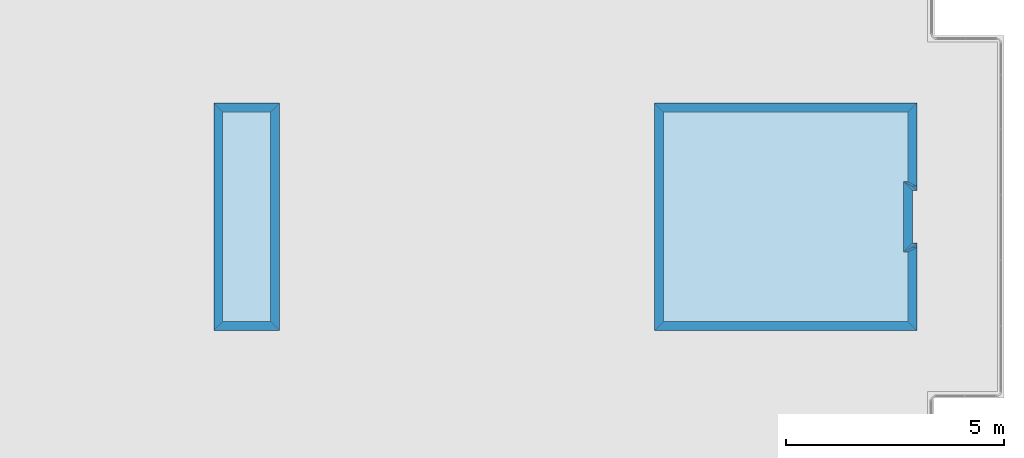
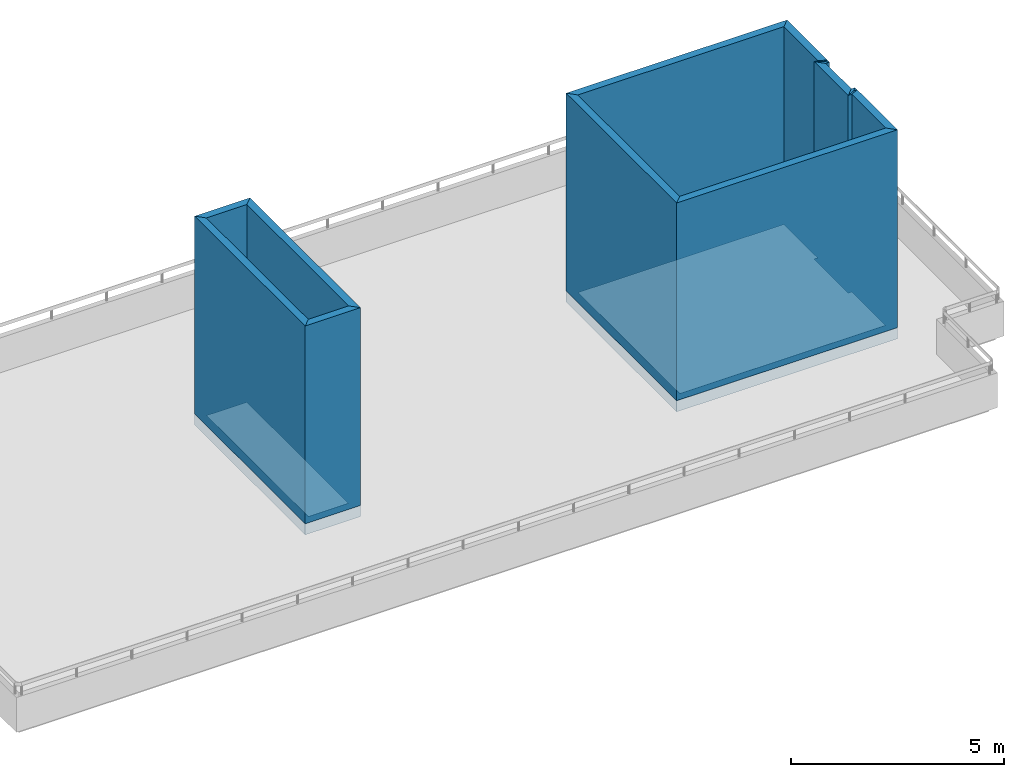
# One storey, part 1 of 34: 14 walls, 4 slabs.
"""IFC2X3 building model written with IfcOpenShell, lengths in metres."""

import ifcopenshell
import ifcopenshell.guid

model = None  # the IFC model being written
_history = None  # IfcOwnerHistory: only IFC2X3 demands one
_inside = {}  # id of a spatial element -> (the spatial element, [elements in it])
_under = {}  # id of a project, library or spatial element -> (it, [spatial elements below it])
_declared = {}  # id of a project -> (the project, [libraries it declares])
_typed = {}  # id of a type object -> (the type object, [elements of that type])
_made_of = {}  # id of a material, layer set ... -> (it, [elements and type objects made of it])


def new_model(schema):
    """Start an empty IFC model of exactly this schema.

    Asked for "IFC4X3", IfcOpenShell would pick the latest addendum, in which some entities
    have other attributes; the version numbers below select the first issue.
    IFC2X3 requires an IfcOwnerHistory on every rooted entity: one is made here for all.
    """
    global model, _history
    if schema == "IFC4X3":
        model = ifcopenshell.file(schema_version=(4, 3, 0, 0))
    else:
        model = ifcopenshell.file(schema=schema)
    _inside.clear()
    _under.clear()
    _declared.clear()
    _typed.clear()
    _made_of.clear()
    _history = None
    if model.schema == "IFC2X3":
        org = make("IfcOrganization", Name="unknown")
        user = make(
            "IfcPersonAndOrganization",
            ThePerson=make("IfcPerson", FamilyName="unknown"),
            TheOrganization=org,
        )
        app = make(
            "IfcApplication",
            ApplicationDeveloper=org,
            Version="unknown",
            ApplicationFullName="unknown",
            ApplicationIdentifier="unknown",
        )
        _history = make(
            "IfcOwnerHistory",
            OwningUser=user,
            OwningApplication=app,
            ChangeAction="ADDED",
            CreationDate=0,
        )
    return model


def make(cls, **values):
    """One entity of the class cls with the attributes given. An attribute that is None is left unset."""
    return model.create_entity(
        cls, **{name: value for name, value in values.items() if value is not None}
    )


def entity(cls, *values):
    """Any entity or typed value of the class cls, its attributes in the order of the schema. None: left unset."""
    e = model.create_entity(cls)
    for i, value in enumerate(values):
        if value is not None:
            e[i] = value
    return e


def rooted(cls, **values):
    """An entity with a GlobalId (a new one), such as an element, a storey or a relation."""
    return make(cls, GlobalId=ifcopenshell.guid.new(), OwnerHistory=_history, **values)


def si_unit(unit_type, name, prefix=None):
    """IfcSIUnit, for example si_unit("LENGTHUNIT", "METRE", prefix="MILLI")."""
    return make("IfcSIUnit", UnitType=unit_type, Prefix=prefix, Name=name)


def converted_unit(unit_type, name, factor, base, dimensions=None, offset=None):
    """IfcConversionBasedUnit, such as the inch: factor (a typed value) times the base unit."""
    return make(
        "IfcConversionBasedUnit"
        if offset is None
        else "IfcConversionBasedUnitWithOffset",
        ConversionOffset=offset,
        Dimensions=None
        if dimensions is None
        else entity("IfcDimensionalExponents", *dimensions),
        UnitType=unit_type,
        Name=name,
        ConversionFactor=make(
            "IfcMeasureWithUnit", ValueComponent=factor, UnitComponent=base
        ),
    )


def derived_unit(unit_type, elements):
    """IfcDerivedUnit: a product of units, each with its exponent."""
    return make(
        "IfcDerivedUnit",
        Elements=[
            make("IfcDerivedUnitElement", Unit=unit, Exponent=power)
            for unit, power in elements
        ],
        UnitType=unit_type,
    )


def assignment(units):
    """IfcUnitAssignment: the units of a project."""
    return None if units is None else make("IfcUnitAssignment", Units=units)


def point(xyz):
    """IfcCartesianPoint."""
    return None if xyz is None else make("IfcCartesianPoint", Coordinates=xyz)


def direction(xyz):
    """IfcDirection."""
    return None if xyz is None else make("IfcDirection", DirectionRatios=xyz)


def frame(location, z_axis=None, x_axis=None):
    """IfcAxis2Placement3D, a coordinate frame: its origin and axes. An axis left out is left unset."""
    return make(
        "IfcAxis2Placement3D",
        Location=point(location),
        Axis=direction(z_axis),
        RefDirection=direction(x_axis),
    )


def origin_with_axes():
    """The frame at (0, 0, 0) with the z axis (0, 0, 1) and the x axis (1, 0, 0) written out."""
    return frame((0.0, 0.0, 0.0), z_axis=(0.0, 0.0, 1.0), x_axis=(1.0, 0.0, 0.0))


def place(relative_to, where):
    """IfcLocalPlacement: puts the frame where relative to a parent placement (None: the world)."""
    return make(
        "IfcLocalPlacement", PlacementRelTo=relative_to, RelativePlacement=where
    )


def context(
    kind, dimensions, precision=None, world=None, true_north=None, identifier=None
):
    """IfcGeometricRepresentationContext, for example the 3D "Model" context."""
    return make(
        "IfcGeometricRepresentationContext",
        ContextIdentifier=identifier,
        ContextType=kind,
        CoordinateSpaceDimension=dimensions,
        Precision=precision,
        WorldCoordinateSystem=world,
        TrueNorth=true_north,
    )


def project(units=None, contexts=None):
    """IfcProject with its units and contexts."""
    return rooted(
        "IfcProject",
        Name="project",
        RepresentationContexts=contexts,
        UnitsInContext=assignment(units),
    )


def spatial(cls, under=None, at=None, **own):
    """A site, building, storey or space (cls), placed at a placement, below another one or the project."""
    s = rooted(cls, ObjectPlacement=at, **own)
    if under is not None:
        _under.setdefault(under.id(), (under, []))[1].append(s)
    return s


def polyline(points):
    """IfcPolyline through the points."""
    return make("IfcPolyline", Points=[point(p) for p in points])


def outline(outer, holes=None, kind="AREA"):
    """IfcArbitraryClosedProfileDef: a profile drawn as a closed curve; with holes, ...WithVoids."""
    if holes is None:
        return make("IfcArbitraryClosedProfileDef", ProfileType=kind, OuterCurve=outer)
    return make(
        "IfcArbitraryProfileDefWithVoids",
        ProfileType=kind,
        OuterCurve=outer,
        InnerCurves=holes,
    )


def extrude(swept, where, along, depth):
    """IfcExtrudedAreaSolid: the profile swept, set in the frame where, extruded along a direction by depth."""
    return make(
        "IfcExtrudedAreaSolid",
        SweptArea=swept,
        Position=where,
        ExtrudedDirection=direction(along),
        Depth=depth,
    )


def shape(context_of_items, identifier, shape_type, items):
    """IfcShapeRepresentation: the items that make up one representation, for example the "Body"."""
    return make(
        "IfcShapeRepresentation",
        ContextOfItems=context_of_items,
        RepresentationIdentifier=identifier,
        RepresentationType=shape_type,
        Items=items,
    )


def material(Name=None, Category=None):
    """IfcMaterial."""
    return make("IfcMaterial", Name=Name, Category=Category)


def layer(
    of_material, thickness, ventilated=None, Name=None, Category=None, Priority=None
):
    """IfcMaterialLayer: one layer of a wall or slab, of a material (None: an air gap)."""
    return make(
        "IfcMaterialLayer",
        Material=of_material,
        LayerThickness=thickness,
        IsVentilated=ventilated,
        Name=Name,
        Category=Category,
        Priority=Priority,
    )


def layer_set(layers, Name=None):
    """IfcMaterialLayerSet."""
    return make("IfcMaterialLayerSet", MaterialLayers=layers, LayerSetName=Name)


def layer_usage(for_layer_set, set_direction, sense, offset, extent=None):
    """IfcMaterialLayerSetUsage: how a layer set lies in its element."""
    return make(
        "IfcMaterialLayerSetUsage",
        ForLayerSet=for_layer_set,
        LayerSetDirection=set_direction,
        DirectionSense=sense,
        OffsetFromReferenceLine=offset,
        ReferenceExtent=extent,
    )


def made_of(thing, what):
    """Note that an element or type object is made of a material, layer set ...; save() writes the relation."""
    if what is not None:
        _made_of.setdefault(what.id(), (what, []))[1].append(thing)
    return thing


def element(
    cls,
    number,
    at=None,
    inside=None,
    cuts=None,
    type_object=None,
    material=None,
    context=None,
    identifier="Body",
    shape_type=None,
    held_by="IfcProductDefinitionShape",
    body=None,
    shapes=None,
    **own,
):
    """One element of the class cls, such as IfcWall. Its Tag is "e" and its number.

    at: its placement. inside: the storey or other place that contains it. cuts: it is an
    opening in that element (IfcRelVoidsElement). A single representation is given by context,
    identifier, shape_type and body (its items); several are given by shapes. held_by: the class
    of the entity that holds the representations. save() writes the other relations.
    """
    e = rooted(cls, Tag="e%d" % number, ObjectPlacement=at, **own)
    if body is not None:
        shapes = [shape(context, identifier, shape_type, body)]
    if shapes is not None:
        e.Representation = make(held_by, Representations=shapes)
    if inside is not None:
        _inside.setdefault(inside.id(), (inside, []))[1].append(e)
    if cuts is not None:
        rooted(
            "IfcRelVoidsElement", RelatingBuildingElement=cuts, RelatedOpeningElement=e
        )
    if type_object is not None:
        _typed.setdefault(type_object.id(), (type_object, []))[1].append(e)
    return made_of(e, material)


def aggregate(whole, parts):
    """IfcRelAggregates: a whole, such as a stair, and the parts it consists of."""
    return rooted("IfcRelAggregates", RelatingObject=whole, RelatedObjects=parts)


def save(model, path):
    """Write the relations noted so far, then the file.

    IfcRelAggregates (storeys below a building ...), IfcRelContainedInSpatialStructure (elements
    in a storey), IfcRelDefinesByType, IfcRelAssociatesMaterial and IfcRelDeclares: one each for
    every whole, place, type object, material and project.
    """
    for whole, parts in _under.values():
        aggregate(whole, parts)
    for where, things in _inside.values():
        rooted(
            "IfcRelContainedInSpatialStructure",
            RelatedElements=things,
            RelatingStructure=where,
        )
    for kind, things in _typed.values():
        rooted("IfcRelDefinesByType", RelatedObjects=things, RelatingType=kind)
    for what, things in _made_of.values():
        rooted("IfcRelAssociatesMaterial", RelatedObjects=things, RelatingMaterial=what)
    for by, libraries in _declared.values():
        rooted("IfcRelDeclares", RelatingContext=by, RelatedDefinitions=libraries)
    model.write(path)


model = new_model("IFC2X3")

# Units and contexts
context_of_model_1 = context(None, 3, world=origin_with_axes())
context_of_model_2 = context(None, 3, world=origin_with_axes())
context_of_model_3 = context(None, 2, world=origin_with_axes())
context_of_model_4 = context(None, 3, world=origin_with_axes())
ifc_project = project(units=[si_unit("LENGTHUNIT", "METRE"), si_unit("AREAUNIT", "SQUARE_METRE"), si_unit("ELECTRICCURRENTUNIT", "AMPERE"), si_unit("ELECTRICVOLTAGEUNIT", "VOLT"), si_unit("ELECTRICRESISTANCEUNIT", "OHM"), si_unit("POWERUNIT", "WATT"), si_unit("MASSUNIT", "GRAM"), si_unit("SOLIDANGLEUNIT", "STERADIAN"), si_unit("THERMODYNAMICTEMPERATUREUNIT", "KELVIN"), si_unit("PRESSUREUNIT", "PASCAL"), si_unit("LUMINOUSFLUXUNIT", "LUMEN"), si_unit("ILLUMINANCEUNIT", "LUX"), si_unit("FREQUENCYUNIT", "HERTZ"), si_unit("VOLUMEUNIT", "CUBIC_METRE"), si_unit("TIMEUNIT", "SECOND"), derived_unit("VOLUMETRICFLOWRATEUNIT", [(si_unit("TIMEUNIT", "SECOND"), -1), (si_unit("VOLUMEUNIT", "CUBIC_METRE"), 1)]), derived_unit("THERMALTRANSMITTANCEUNIT", [(si_unit("AREAUNIT", "SQUARE_METRE"), -1), (si_unit("THERMODYNAMICTEMPERATUREUNIT", "KELVIN"), -1), (si_unit("POWERUNIT", "WATT"), 1)]), converted_unit("PLANEANGLEUNIT", "DEGREE", entity("IfcPlaneAngleMeasure", 57.29577951308232), si_unit("PLANEANGLEUNIT", "RADIAN"), dimensions=[0, 0, 0, 0, 0, 0, 0])], contexts=[context_of_model_1, context_of_model_2, context_of_model_3, context_of_model_4])

# Site, building, storey
site = spatial("IfcSite", under=ifc_project, CompositionType="ELEMENT")
building_placement = place(None, origin_with_axes())
building = spatial("IfcBuilding", under=site, at=building_placement, Name="Tower", CompositionType="ELEMENT")
storey_placement = place(building_placement, frame((0.0, 0.0, 79.0), z_axis=(0.0, 0.0, 1.0), x_axis=(1.0, 0.0, 0.0)))
storey = spatial("IfcBuildingStorey", under=building, at=storey_placement, Name="Level 2", CompositionType="ELEMENT", Elevation=79.0)

# Slabs
ifc_material_1 = material()
ifc_layer_1 = layer(ifc_material_1, 0.3199999928474426, ventilated=False)
ifc_layer_set_1 = layer_set([ifc_layer_1])
ifc_layer_usage_1 = layer_usage(ifc_layer_set_1, "AXIS2", "POSITIVE", 0.0)
slab_1_placement = place(storey_placement, frame((0.1000000014901161, 1.399999976158142, 0.0), z_axis=(0.0, 0.0, 1.0), x_axis=(1.0, 0.0, 0.0)))
element("IfcSlab", 1, at=slab_1_placement, inside=storey, material=ifc_layer_usage_1, PredefinedType="FLOOR", context=context_of_model_1, shape_type="SweptSolid", body=[
    extrude(outline(polyline([(0.0, 0.0), (2.000000119209291, 0.0), (2.000000123679635, 0.09999991208314658), (3.199999932944773, 0.09999991089263771), (3.199999928474423, -1.430511357369829e-07), (5.200000405311582, -1.430511517241935e-07), (5.200000673532468, 5.999999864399424), (2.682208898319164e-07, 6.000000096857542), (0.0, 0.0)])), frame((0.0, 0.0, 0.0), z_axis=(0.0, 0.0, 1.0), x_axis=(-4.470348091700783e-08, 0.9999999999999991, 0.0)), (0.0, 0.0, -1.0), 0.3199999928474426),
])
slab_2_placement = place(storey_placement, frame((-15.98883533477783, 1.399999976158142, 0.0), z_axis=(0.0, 0.0, 1.0), x_axis=(1.0, 0.0, 0.0)))
element("IfcSlab", 2, at=slab_2_placement, inside=storey, material=ifc_layer_usage_1, PredefinedType="FLOOR", context=context_of_model_1, shape_type="SweptSolid", body=[
    extrude(outline(polyline([(0.0, 0.0), (1.5, 0.0), (1.5, 5.200000405311585), (0.0, 5.200000405311585), (0.0, 0.0)])), origin_with_axes(), (0.0, 0.0, -1.0), 0.3199999928474426),
])
slab_3_placement = place(storey_placement, frame((-0.1000000089406967, 1.600000023841858, 0.0), z_axis=(0.0, 0.0, 1.0), x_axis=(1.0, 0.0, 0.0)))
element("IfcSlab", 3, at=slab_3_placement, inside=storey, material=ifc_layer_usage_1, PredefinedType="FLOOR", context=context_of_model_1, shape_type="SweptSolid", body=[
    extrude(outline(polyline([(0.0, 0.0), (1.60000002384186, -1.323488980084844e-23), (1.600000028498468, 0.09999990463256826), (3.19999969471246, 0.09999991953374611), (3.199999690055844, -1.490115952851313e-07), (4.80000054836273, -1.490116341429366e-07), (4.800001285970215, 5.600000053644131), (2.607703299128956e-07, 5.600000277161593), (0.0, 0.0)])), frame((0.0, 0.0, 0.0), z_axis=(0.0, 0.0, 1.0), x_axis=(-4.65661280368845e-08, 0.999999999999999, 0.0)), (0.0, 0.0, 1.0), 0.01),
])
slab_4_placement = place(storey_placement, frame((-15.7888355255127, 1.600000023841858, 0.0), z_axis=(0.0, 0.0, 1.0), x_axis=(1.0, 0.0, 0.0)))
element("IfcSlab", 4, at=slab_4_placement, inside=storey, material=ifc_layer_usage_1, PredefinedType="FLOOR", context=context_of_model_1, shape_type="SweptSolid", body=[
    extrude(outline(polyline([(0.0, 0.0), (1.100000381469727, 0.0), (1.100000381469727, 4.800000548362732), (0.0, 4.800000548362732), (0.0, 0.0)])), origin_with_axes(), (0.0, 0.0, 1.0), 0.01),
])

# Walls
ifc_material_2 = material(Name="Layer-Yttervegg 20.0cm")
ifc_layer_2 = layer(ifc_material_2, 0.2000000029802322, ventilated=False)
ifc_layer_set_2 = layer_set([ifc_layer_2], Name="ML-Yttervegg 20.0cm - 0.200")
ifc_layer_usage_2 = layer_usage(ifc_layer_set_2, "AXIS2", "POSITIVE", 0.0)
wall_1_placement = place(storey_placement, frame((0.09999991208314896, 3.400000095367432, 0.0), z_axis=(0.0, 0.0, 1.0), x_axis=(-1.0, -8.742277657347586e-08, 0.0)))
element("IfcWallStandardCase", 5, at=wall_1_placement, inside=storey, material=ifc_layer_usage_2, Name="Yttervegg 20.0cm", context=context_of_model_1, shape_type="SweptSolid", body=[
    extrude(outline(polyline([(0.0, 0.0), (0.0999999120831467, 0.0), (0.2999999299645421, 0.2000000476837162), (0.1999999880790708, 0.2000000476837158), (0.0, 0.0)])), frame((0.0, 0.0, 0.0), z_axis=(0.0, 0.0, 1.0), x_axis=(0.9999999999999961, -8.742278149038243e-08, 0.0)), (0.0, 0.0, 1.0), 5.680000007152557),
])
wall_2_placement = place(storey_placement, frame((-5.245365741757269e-08, 4.599999904632568, 0.0), z_axis=(0.0, 0.0, 1.0), x_axis=(1.0, 0.0, 0.0)))
element("IfcWallStandardCase", 6, at=wall_2_placement, inside=storey, material=ifc_layer_usage_2, Name="Yttervegg 20.0cm", context=context_of_model_1, shape_type="SweptSolid", body=[
    extrude(outline(polyline([(0.0, 0.0), (0.1000000539437735, 0.0), (-0.0999999564870393, 0.1999998092651367), (-0.2000000250323808, 0.1999998092651367), (0.0, 0.0)])), origin_with_axes(), (0.0, 0.0, 1.0), 5.680000007152557),
])
wall_3_placement = place(storey_placement, frame((0.1000000014901161, 1.399999976158142, 0.0), z_axis=(0.0, 0.0, 1.0), x_axis=(-4.371138828673793e-08, 1.0, 0.0)))
element("IfcWallStandardCase", 7, at=wall_3_placement, inside=storey, material=ifc_layer_usage_2, Name="Yttervegg 20.0cm", context=context_of_model_1, shape_type="SweptSolid", body=[
    extrude(outline(polyline([(0.0, 0.0), (2.000000119209291, 0.0), (1.800000080466272, 0.2000000044703497), (0.2000000566244123, 0.2000000014901143), (0.0, 0.0)])), frame((0.0, 0.0, 0.0), z_axis=(0.0, 0.0, 1.0), x_axis=(1.0, 9.92090919679804e-10, 0.0)), (0.0, 0.0, 1.0), 5.680000007152557),
])
ifc_material_3 = material()
ifc_layer_3 = layer(ifc_material_3, 0.1, ventilated=False)
ifc_layer_set_3 = layer_set([ifc_layer_3])
ifc_layer_usage_3 = layer_usage(ifc_layer_set_3, "AXIS2", "POSITIVE", 0.0)
wall_4_placement = place(storey_placement, frame((0.09999991953372955, 3.299999952316284, 0.0), z_axis=(0.0, 0.0, 1.0), x_axis=(-1.0, -8.742277657347586e-08, 0.0)))
element("IfcWallStandardCase", 8, at=wall_4_placement, inside=storey, material=ifc_layer_usage_3, context=context_of_model_1, shape_type="SweptSolid", body=[
    extrude(outline(polyline([(0.0, 0.0), (0.09999991208314898, 0.0), (0.2999999076128005, 0.09999990463256865), (0.2000000029802322, 0.09999990463256886), (0.0, 0.0)])), frame((0.0, 0.0, 0.0), z_axis=(0.0, 0.0, 1.0), x_axis=(0.9999999999999961, -8.742278149038043e-08, 0.0)), (0.0, 0.0, 1.0), 5.680000007152557),
])
wall_5_placement = place(storey_placement, frame((2.289834988289385e-15, 3.400000095367432, 0.0), z_axis=(0.0, 0.0, 1.0), x_axis=(-4.371138828673793e-08, 1.0, 0.0)))
element("IfcWallStandardCase", 9, at=wall_5_placement, inside=storey, material=ifc_layer_usage_2, Name="Yttervegg 20.0cm", context=context_of_model_1, shape_type="SweptSolid", body=[
    extrude(outline(polyline([(0.0, 0.0), (1.199999809265139, 0.0), (1.399999627272554, 0.2000000162901109), (-0.2000000389414378, 0.1999999968213532), (0.0, 0.0)])), frame((0.0, 0.0, 0.0), z_axis=(0.0, 0.0, 1.0), x_axis=(1.0, 3.53822923663501e-17, 0.0)), (0.0, 0.0, 1.0), 5.680000007152557),
])
wall_6_placement = place(storey_placement, frame((-7.450580596923828e-08, 4.699999809265137, 0.0), z_axis=(0.0, 0.0, 1.0), x_axis=(1.0, 0.0, 0.0)))
element("IfcWallStandardCase", 10, at=wall_6_placement, inside=storey, material=ifc_layer_usage_3, context=context_of_model_1, shape_type="SweptSolid", body=[
    extrude(outline(polyline([(0.0, 0.0), (0.1000000685453415, 0.0), (-0.09999993443489075, 0.09999990463256836), (-0.2000000029802322, 0.09999990463256836), (0.0, 0.0)])), origin_with_axes(), (0.0, 0.0, 1.0), 5.680000007152557),
])
wall_7_placement = place(storey_placement, frame((0.1000000014901161, 4.599999904632568, 0.0), z_axis=(0.0, 0.0, 1.0), x_axis=(-4.371138828673793e-08, 1.0, 0.0)))
element("IfcWallStandardCase", 11, at=wall_7_placement, inside=storey, material=ifc_layer_usage_2, Name="Yttervegg 20.0cm", context=context_of_model_1, shape_type="SweptSolid", body=[
    extrude(outline(polyline([(0.0, 0.0), (2.00000047683716, 0.0), (1.800000676512718, 0.2000000044703375), (0.1999998182058313, 0.2000000014901266), (0.0, 0.0)])), frame((0.0, 0.0, 0.0), z_axis=(0.0, 0.0, 1.0), x_axis=(1.0, 9.920829221486003e-10, 0.0)), (0.0, 0.0, 1.0), 5.680000007152557),
])
wall_8_placement = place(storey_placement, frame((0.09999991208314896, 6.600000381469727, 0.0), z_axis=(0.0, 0.0, 1.0), x_axis=(-1.0, -8.742277657347586e-08, 0.0)))
element("IfcWallStandardCase", 12, at=wall_8_placement, inside=storey, material=ifc_layer_usage_2, Name="Yttervegg 20.0cm", context=context_of_model_1, shape_type="SweptSolid", body=[
    extrude(outline(polyline([(0.0, 0.0), (6.000000007450581, 0.0), (5.800000198185445, 0.1999993324279791), (0.1999999955296517, 0.1999998092651371), (0.0, 0.0)])), frame((0.0, 0.0, 0.0), z_axis=(0.0, 0.0, 1.0), x_axis=(0.9999999999999961, -8.742278001763112e-08, 0.0)), (0.0, 0.0, 1.0), 5.680000007152557),
])
wall_9_placement = place(storey_placement, frame((-5.900000095367432, 6.600000381469727, 0.0), z_axis=(0.0, 0.0, 1.0), x_axis=(-4.371138828673793e-08, -1.0, 0.0)))
element("IfcWallStandardCase", 13, at=wall_9_placement, inside=storey, material=ifc_layer_usage_2, Name="Yttervegg 20.0cm", context=context_of_model_1, shape_type="SweptSolid", body=[
    extrude(outline(polyline([(0.0, 0.0), (5.200000405311585, 2.646977960169689e-23), (5.00000035762787, 0.1999998092651363), (0.1999993324279792, 0.1999998092651359), (0.0, 0.0)])), frame((0.0, 0.0, 0.0), z_axis=(0.0, 0.0, 1.0), x_axis=(0.999999999999999, 4.371138990129808e-08, 0.0)), (0.0, 0.0, 1.0), 5.680000007152557),
])
wall_10_placement = place(storey_placement, frame((-5.900000095367432, 1.399999976158142, 0.0), z_axis=(0.0, 0.0, 1.0), x_axis=(1.0, 0.0, 0.0)))
element("IfcWallStandardCase", 14, at=wall_10_placement, inside=storey, material=ifc_layer_usage_2, Name="Yttervegg 20.0cm", context=context_of_model_1, shape_type="SweptSolid", body=[
    extrude(outline(polyline([(0.0, 0.0), (6.000000096857548, 0.0), (5.800000086426735, 0.2000000476837158), (0.1999998092651367, 0.2000000476837158), (0.0, 0.0)])), origin_with_axes(), (0.0, 0.0, 1.0), 5.680000007152557),
])
wall_11_placement = place(storey_placement, frame((-15.98883533477783, 1.399999976158142, 0.0), z_axis=(0.0, 0.0, 1.0), x_axis=(1.0, 0.0, 0.0)))
element("IfcWallStandardCase", 15, at=wall_11_placement, inside=storey, material=ifc_layer_usage_2, Name="Yttervegg 20.0cm", context=context_of_model_1, shape_type="SweptSolid", body=[
    extrude(outline(polyline([(0.0, 0.0), (1.5, 0.0), (1.300000190734863, 0.2000000476837158), (0.1999998092651367, 0.2000000476837158), (0.0, 0.0)])), origin_with_axes(), (0.0, 0.0, 1.0), 5.680000007152557),
])
wall_12_placement = place(storey_placement, frame((-14.48883533477783, 1.399999976158142, 0.0), z_axis=(0.0, 0.0, 1.0), x_axis=(-4.371138828673793e-08, 1.0, 0.0)))
element("IfcWallStandardCase", 16, at=wall_12_placement, inside=storey, material=ifc_layer_usage_2, Name="Yttervegg 20.0cm", context=context_of_model_1, shape_type="SweptSolid", body=[
    extrude(outline(polyline([(0.0, 0.0), (5.200000405311585, 0.0), (5.00000059604645, 0.1999998092651364), (0.2000000476837157, 0.1999998092651355), (0.0, 0.0)])), frame((0.0, 0.0, 0.0), z_axis=(0.0, 0.0, 1.0), x_axis=(0.999999999999999, -4.371139007210162e-08, 0.0)), (0.0, 0.0, 1.0), 5.680000007152557),
])
wall_13_placement = place(storey_placement, frame((-14.48883533477783, 6.600000381469727, 0.0), z_axis=(0.0, 0.0, 1.0), x_axis=(-1.0, -8.742277657347586e-08, 0.0)))
element("IfcWallStandardCase", 17, at=wall_13_placement, inside=storey, material=ifc_layer_usage_2, Name="Yttervegg 20.0cm", context=context_of_model_1, shape_type="SweptSolid", body=[
    extrude(outline(polyline([(0.0, 0.0), (1.500000000000001, 0.0), (1.300000190734862, 0.1999998092651373), (0.1999998092651364, 0.1999998092651368), (0.0, 0.0)])), frame((0.0, 0.0, 0.0), z_axis=(0.0, 0.0, 1.0), x_axis=(0.9999999999999961, -8.742278012618951e-08, 0.0)), (0.0, 0.0, 1.0), 5.680000007152557),
])
wall_14_placement = place(storey_placement, frame((-15.98883533477783, 6.600000381469727, 0.0), z_axis=(0.0, 0.0, 1.0), x_axis=(-4.371138828673793e-08, -1.0, 0.0)))
element("IfcWallStandardCase", 18, at=wall_14_placement, inside=storey, material=ifc_layer_usage_2, Name="Yttervegg 20.0cm", context=context_of_model_1, shape_type="SweptSolid", body=[
    extrude(outline(polyline([(0.0, 0.0), (5.200000405311585, 0.0), (5.00000035762787, 0.1999998092651355), (0.1999998092651366, 0.1999998092651364), (0.0, 0.0)])), frame((0.0, 0.0, 0.0), z_axis=(0.0, 0.0, 1.0), x_axis=(0.999999999999999, 4.371139007210162e-08, 0.0)), (0.0, 0.0, 1.0), 5.680000007152557),
])

save(model, "model.ifc")
